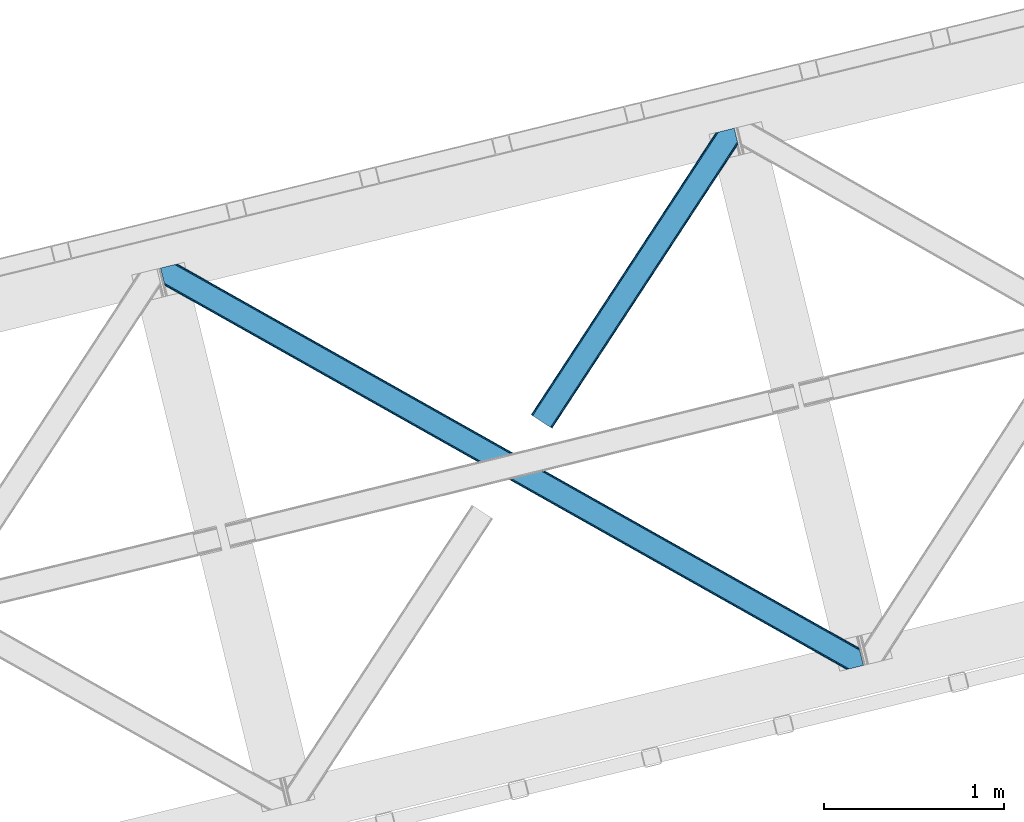
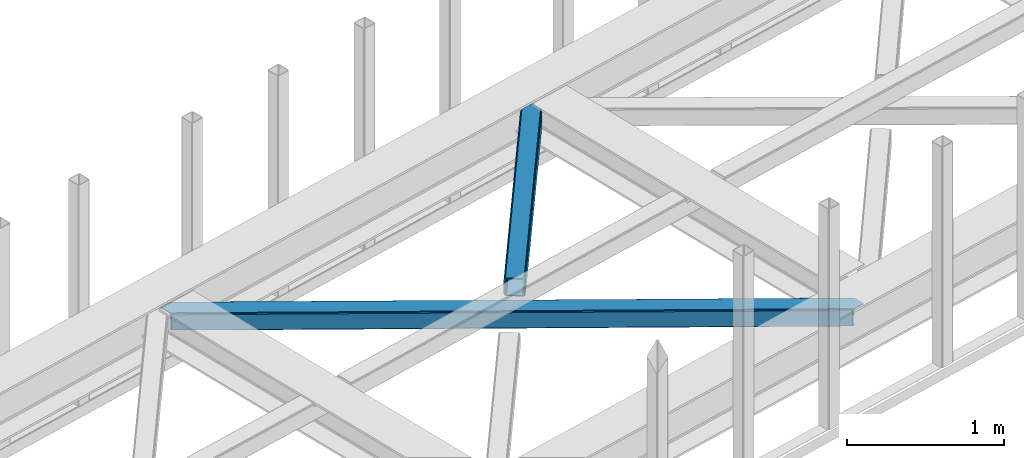
# One storey, part 35 of 66: 2 members.
"""IFC4 building model written with IfcOpenShell, lengths in millimetres."""

import ifcopenshell
import ifcopenshell.guid

model = None  # the IFC model being written
_history = None  # IfcOwnerHistory: only IFC2X3 demands one
_inside = {}  # id of a spatial element -> (the spatial element, [elements in it])
_under = {}  # id of a project, library or spatial element -> (it, [spatial elements below it])
_declared = {}  # id of a project -> (the project, [libraries it declares])
_typed = {}  # id of a type object -> (the type object, [elements of that type])
_made_of = {}  # id of a material, layer set ... -> (it, [elements and type objects made of it])


def new_model(schema):
    """Start an empty IFC model of exactly this schema.

    Asked for "IFC4X3", IfcOpenShell would pick the latest addendum, in which some entities
    have other attributes; the version numbers below select the first issue.
    IFC2X3 requires an IfcOwnerHistory on every rooted entity: one is made here for all.
    """
    global model, _history
    if schema == "IFC4X3":
        model = ifcopenshell.file(schema_version=(4, 3, 0, 0))
    else:
        model = ifcopenshell.file(schema=schema)
    _inside.clear()
    _under.clear()
    _declared.clear()
    _typed.clear()
    _made_of.clear()
    _history = None
    if model.schema == "IFC2X3":
        org = make("IfcOrganization", Name="unknown")
        user = make(
            "IfcPersonAndOrganization",
            ThePerson=make("IfcPerson", FamilyName="unknown"),
            TheOrganization=org,
        )
        app = make(
            "IfcApplication",
            ApplicationDeveloper=org,
            Version="unknown",
            ApplicationFullName="unknown",
            ApplicationIdentifier="unknown",
        )
        _history = make(
            "IfcOwnerHistory",
            OwningUser=user,
            OwningApplication=app,
            ChangeAction="ADDED",
            CreationDate=0,
        )
    return model


def make(cls, **values):
    """One entity of the class cls with the attributes given. An attribute that is None is left unset."""
    return model.create_entity(
        cls, **{name: value for name, value in values.items() if value is not None}
    )


def entity(cls, *values):
    """Any entity or typed value of the class cls, its attributes in the order of the schema. None: left unset."""
    e = model.create_entity(cls)
    for i, value in enumerate(values):
        if value is not None:
            e[i] = value
    return e


def rooted(cls, **values):
    """An entity with a GlobalId (a new one), such as an element, a storey or a relation."""
    return make(cls, GlobalId=ifcopenshell.guid.new(), OwnerHistory=_history, **values)


def si_unit(unit_type, name, prefix=None):
    """IfcSIUnit, for example si_unit("LENGTHUNIT", "METRE", prefix="MILLI")."""
    return make("IfcSIUnit", UnitType=unit_type, Prefix=prefix, Name=name)


def converted_unit(unit_type, name, factor, base, dimensions=None, offset=None):
    """IfcConversionBasedUnit, such as the inch: factor (a typed value) times the base unit."""
    return make(
        "IfcConversionBasedUnit"
        if offset is None
        else "IfcConversionBasedUnitWithOffset",
        ConversionOffset=offset,
        Dimensions=None
        if dimensions is None
        else entity("IfcDimensionalExponents", *dimensions),
        UnitType=unit_type,
        Name=name,
        ConversionFactor=make(
            "IfcMeasureWithUnit", ValueComponent=factor, UnitComponent=base
        ),
    )


def derived_unit(unit_type, elements):
    """IfcDerivedUnit: a product of units, each with its exponent."""
    return make(
        "IfcDerivedUnit",
        Elements=[
            make("IfcDerivedUnitElement", Unit=unit, Exponent=power)
            for unit, power in elements
        ],
        UnitType=unit_type,
    )


def assignment(units):
    """IfcUnitAssignment: the units of a project."""
    return None if units is None else make("IfcUnitAssignment", Units=units)


def point(xyz):
    """IfcCartesianPoint."""
    return None if xyz is None else make("IfcCartesianPoint", Coordinates=xyz)


def direction(xyz):
    """IfcDirection."""
    return None if xyz is None else make("IfcDirection", DirectionRatios=xyz)


def frame(location, z_axis=None, x_axis=None):
    """IfcAxis2Placement3D, a coordinate frame: its origin and axes. An axis left out is left unset."""
    return make(
        "IfcAxis2Placement3D",
        Location=point(location),
        Axis=direction(z_axis),
        RefDirection=direction(x_axis),
    )


def origin():
    """The frame at (0, 0, 0) with its axes left unset."""
    return frame((0.0, 0.0, 0.0))


def place(relative_to, where):
    """IfcLocalPlacement: puts the frame where relative to a parent placement (None: the world)."""
    return make(
        "IfcLocalPlacement", PlacementRelTo=relative_to, RelativePlacement=where
    )


def context(
    kind, dimensions, precision=None, world=None, true_north=None, identifier=None
):
    """IfcGeometricRepresentationContext, for example the 3D "Model" context."""
    return make(
        "IfcGeometricRepresentationContext",
        ContextIdentifier=identifier,
        ContextType=kind,
        CoordinateSpaceDimension=dimensions,
        Precision=precision,
        WorldCoordinateSystem=world,
        TrueNorth=true_north,
    )


def subcontext(parent, identifier, kind, view, scale=None):
    """IfcGeometricRepresentationSubContext, for example "Body" below "Model"."""
    return make(
        "IfcGeometricRepresentationSubContext",
        ContextIdentifier=identifier,
        ContextType=kind,
        ParentContext=parent,
        TargetScale=scale,
        TargetView=view,
    )


def project(units=None, contexts=None):
    """IfcProject with its units and contexts."""
    return rooted(
        "IfcProject",
        Name="project",
        RepresentationContexts=contexts,
        UnitsInContext=assignment(units),
    )


def spatial(cls, under=None, at=None, **own):
    """A site, building, storey or space (cls), placed at a placement, below another one or the project."""
    s = rooted(cls, ObjectPlacement=at, **own)
    if under is not None:
        _under.setdefault(under.id(), (under, []))[1].append(s)
    return s


def point_list(points):
    """IfcCartesianPointList2D or 3D."""
    cls = (
        "IfcCartesianPointList2D" if len(points[0]) == 2 else "IfcCartesianPointList3D"
    )
    return make(cls, CoordList=points)


def triangles(points, corners, closed=None, point_numbers=None):
    """IfcTriangulatedFaceSet: each triangle names its three corners, points numbered from 1."""
    return make(
        "IfcTriangulatedFaceSet",
        Coordinates=point_list(points),
        Closed=closed,
        CoordIndex=corners,
        PnIndex=point_numbers,
    )


def shape(context_of_items, identifier, shape_type, items):
    """IfcShapeRepresentation: the items that make up one representation, for example the "Body"."""
    return make(
        "IfcShapeRepresentation",
        ContextOfItems=context_of_items,
        RepresentationIdentifier=identifier,
        RepresentationType=shape_type,
        Items=items,
    )


def made_of(thing, what):
    """Note that an element or type object is made of a material, layer set ...; save() writes the relation."""
    if what is not None:
        _made_of.setdefault(what.id(), (what, []))[1].append(thing)
    return thing


def type_object(cls, material=None, **own):
    """A type object (cls), such as IfcWallType, which elements share."""
    return made_of(rooted(cls, **own), material)


def element(
    cls,
    number,
    at=None,
    inside=None,
    cuts=None,
    type_object=None,
    material=None,
    context=None,
    identifier="Body",
    shape_type=None,
    held_by="IfcProductDefinitionShape",
    body=None,
    shapes=None,
    **own,
):
    """One element of the class cls, such as IfcWall. Its Tag is "e" and its number.

    at: its placement. inside: the storey or other place that contains it. cuts: it is an
    opening in that element (IfcRelVoidsElement). A single representation is given by context,
    identifier, shape_type and body (its items); several are given by shapes. held_by: the class
    of the entity that holds the representations. save() writes the other relations.
    """
    e = rooted(cls, Tag="e%d" % number, ObjectPlacement=at, **own)
    if body is not None:
        shapes = [shape(context, identifier, shape_type, body)]
    if shapes is not None:
        e.Representation = make(held_by, Representations=shapes)
    if inside is not None:
        _inside.setdefault(inside.id(), (inside, []))[1].append(e)
    if cuts is not None:
        rooted(
            "IfcRelVoidsElement", RelatingBuildingElement=cuts, RelatedOpeningElement=e
        )
    if type_object is not None:
        _typed.setdefault(type_object.id(), (type_object, []))[1].append(e)
    return made_of(e, material)


def aggregate(whole, parts):
    """IfcRelAggregates: a whole, such as a stair, and the parts it consists of."""
    return rooted("IfcRelAggregates", RelatingObject=whole, RelatedObjects=parts)


def save(model, path):
    """Write the relations noted so far, then the file.

    IfcRelAggregates (storeys below a building ...), IfcRelContainedInSpatialStructure (elements
    in a storey), IfcRelDefinesByType, IfcRelAssociatesMaterial and IfcRelDeclares: one each for
    every whole, place, type object, material and project.
    """
    for whole, parts in _under.values():
        aggregate(whole, parts)
    for where, things in _inside.values():
        rooted(
            "IfcRelContainedInSpatialStructure",
            RelatedElements=things,
            RelatingStructure=where,
        )
    for kind, things in _typed.values():
        rooted("IfcRelDefinesByType", RelatedObjects=things, RelatingType=kind)
    for what, things in _made_of.values():
        rooted("IfcRelAssociatesMaterial", RelatedObjects=things, RelatingMaterial=what)
    for by, libraries in _declared.values():
        rooted("IfcRelDeclares", RelatingContext=by, RelatedDefinitions=libraries)
    model.write(path)


model = new_model("IFC4")

# Units and contexts
model_context = context("Model", 3, precision=0.01, world=origin(), true_north=direction((6.12303176911189e-17, 1.0)))
plan_context = context("Plan", 3, precision=0.01, world=origin(), true_north=direction((6.12303176911189e-17, 1.0)))
body_context = subcontext(model_context, "Body", "Model", "MODEL_VIEW")
ifc_project = project(units=[si_unit("LENGTHUNIT", "METRE", prefix="MILLI"), si_unit("AREAUNIT", "SQUARE_METRE"), si_unit("VOLUMEUNIT", "CUBIC_METRE"), converted_unit("PLANEANGLEUNIT", "DEGREE", entity("IfcRatioMeasure", 0.0174532925199433), si_unit("PLANEANGLEUNIT", "RADIAN"), dimensions=[0, 0, 0, 0, 0, 0, 0]), si_unit("MASSUNIT", "GRAM", prefix="KILO"), derived_unit("MASSDENSITYUNIT", [(si_unit("MASSUNIT", "GRAM", prefix="KILO"), 1), (si_unit("LENGTHUNIT", "METRE"), -3)]), derived_unit("MOMENTOFINERTIAUNIT", [(si_unit("LENGTHUNIT", "METRE"), 4)]), si_unit("TIMEUNIT", "SECOND"), si_unit("FREQUENCYUNIT", "HERTZ"), si_unit("THERMODYNAMICTEMPERATUREUNIT", "DEGREE_CELSIUS"), derived_unit("THERMALTRANSMITTANCEUNIT", [(si_unit("MASSUNIT", "GRAM", prefix="KILO"), 1), (si_unit("THERMODYNAMICTEMPERATUREUNIT", "KELVIN"), -1), (si_unit("TIMEUNIT", "SECOND"), -3)]), derived_unit("VOLUMETRICFLOWRATEUNIT", [(si_unit("LENGTHUNIT", "METRE"), 3), (si_unit("TIMEUNIT", "SECOND"), -1)]), derived_unit("MASSFLOWRATEUNIT", [(si_unit("MASSUNIT", "GRAM", prefix="KILO"), 1), (si_unit("TIMEUNIT", "SECOND"), -1)]), derived_unit("ROTATIONALFREQUENCYUNIT", [(si_unit("TIMEUNIT", "SECOND"), -1)]), si_unit("ELECTRICCURRENTUNIT", "AMPERE"), si_unit("ELECTRICVOLTAGEUNIT", "VOLT"), si_unit("POWERUNIT", "WATT"), si_unit("FORCEUNIT", "NEWTON", prefix="KILO"), si_unit("ILLUMINANCEUNIT", "LUX"), si_unit("LUMINOUSFLUXUNIT", "LUMEN"), si_unit("LUMINOUSINTENSITYUNIT", "CANDELA"), derived_unit("USERDEFINED", [(si_unit("MASSUNIT", "GRAM", prefix="KILO"), -1), (si_unit("LENGTHUNIT", "METRE"), -2), (si_unit("TIMEUNIT", "SECOND"), 3), (si_unit("LUMINOUSFLUXUNIT", "LUMEN"), 1)]), derived_unit("LINEARVELOCITYUNIT", [(si_unit("LENGTHUNIT", "METRE"), 1), (si_unit("TIMEUNIT", "SECOND"), -1)]), si_unit("PRESSUREUNIT", "PASCAL"), derived_unit("USERDEFINED", [(si_unit("LENGTHUNIT", "METRE"), -2), (si_unit("MASSUNIT", "GRAM", prefix="KILO"), 1), (si_unit("TIMEUNIT", "SECOND"), -2)]), derived_unit("LINEARFORCEUNIT", [(si_unit("MASSUNIT", "GRAM", prefix="KILO"), 1), (si_unit("LENGTHUNIT", "METRE"), 1), (si_unit("TIMEUNIT", "SECOND"), -2), (si_unit("LENGTHUNIT", "METRE"), -1)]), derived_unit("PLANARFORCEUNIT", [(si_unit("MASSUNIT", "GRAM", prefix="KILO"), 1), (si_unit("LENGTHUNIT", "METRE"), 1), (si_unit("TIMEUNIT", "SECOND"), -2), (si_unit("LENGTHUNIT", "METRE"), -2)])], contexts=[model_context, plan_context])

# Site, building, storey
site_placement = place(None, origin())
site = spatial("IfcSite", under=ifc_project, at=site_placement, CompositionType="ELEMENT")
building_placement = place(site_placement, origin())
building = spatial("IfcBuilding", under=site, at=building_placement, CompositionType="ELEMENT")
storey_placement = place(building_placement, frame((0.0, 0.0, 19800.0)))
storey = spatial("IfcBuildingStorey", under=building, at=storey_placement, Name="06", CompositionType="ELEMENT", Elevation=19800.0)

# Members
member_type_1 = type_object("IfcMemberType", PredefinedType="BRACE")
member_1_placement = place(storey_placement, frame((-36508.39, 9647.05, 3824.0)))
element("IfcMember", 1, at=member_1_placement, inside=storey, type_object=member_type_1, ObjectType="Steel Horizontal Brace", PredefinedType="BRACE", context=body_context, shape_type="Tessellation", body=[
    triangles([(3809.34190063476, 0.0, 122.499499511719), (3811.23480834961, 0.461599731444949, 129.196765136719), (23.4590332031221, 2133.54825897217, 129.196765136719), (23.8915649414048, 2131.77511138916, 122.499499511719), (3816.62982788086, 1.77663574218786, 134.87548828125), (22.2288757324204, 2138.59446258545, 134.87548828125), (3824.70607910156, 3.74570159912037, 138.668280029298), (20.3871276855498, 2146.14632720947, 138.668280029298), (3834.23107910156, 6.06765289306531, 140.00075683594), (18.2151672363252, 2155.05508575439, 140.00075683594), (1916.9806640625, 1065.68088226318, 17.5012573242202), (2556.11839599609, 705.752851867675, 17.5012573242202), (3195.25147705078, 345.823658752441, 17.5012573242202), (3809.34190063476, 0.0, 17.5012573242202), (1277.84758300781, 1425.61007537842, 17.5012573242202), (638.712176513669, 1785.53926849365, 17.5012573242202), (23.8915649414048, 2131.77511138916, 17.5012573242202), (3885.46283569336, 97.7219421386708, 140.00075683594), (3903.67800292969, 22.9956893920898, 140.00075683594), (69.4469238281235, 2246.70995635986, 140.00075683594), (0.0, 2229.78191986084, 140.00075683594), (3883.29087524414, 106.63011932373, 138.668280029298), (78.971923828125, 2249.03190765381, 138.668280029298), (3881.44912719727, 114.183146667479, 134.87548828125), (87.0458496093779, 2251.00039215088, 134.87548828125), (3880.21896972656, 119.229350280761, 129.196765136719), (92.4408691406279, 2252.31542816162, 129.196765136719), (3879.78643798828, 121.001335144043, 122.499499511719), (94.3384277343721, 2252.77702789307, 122.499499511719), (3265.41928710938, 466.982542419433, 17.5012573242202), (3879.78643798828, 121.001335144043, 17.5012573242202), (2626.2955078125, 826.904759216308, 17.5012573242202), (1987.16940307617, 1186.82813873291, 17.5012573242202), (708.921844482422, 1906.67257232666, 17.5012573242202), (94.3384277343721, 2252.77702789307, 17.5012573242202), (1348.0456237793, 1546.75035552978, 17.5012573242202), (82.4856628417983, 2249.88766937256, 122.197192382813), (69.0143920898408, 2246.60531158447, 131.668707275392), (59.4893920898467, 2244.28336029053, 133.001184082033), (0.0, 2229.78191986084, 133.001184082033), (77.0906433105483, 2248.57263336182, 127.873590087893), (84.3808959960952, 2250.35043182373, 24.5008300781265), (77.0906433105483, 2248.57263336182, 12.1248413085959), (91.582781982419, 2252.10613861084, 9.49942016601563), (82.4856628417983, 2249.88766937256, 17.8035644531265), (84.3808959960952, 2250.35043182373, 115.499926757813), (72.3118652343765, 2247.40875091553, 9.49942016601563), (92.0548461914077, 2252.22124786377, 10.8691040039084), (1983.49055786133, 1180.86803741455, 24.5008300781265), (3882.05839233398, 111.689112854003, 115.499926757813), (2626.78850097656, 818.593638610839, 24.5008300781265), (3270.08876953125, 456.319239807128, 24.5008300781265), (3882.05839233398, 111.689112854003, 24.5008300781265), (1340.19028930664, 1543.14127349854, 24.5008300781265), (696.892346191409, 1905.41567230225, 24.5008300781265), (3882.48859863281, 109.917127990722, 122.197192382813), (3883.71875610352, 104.870924377441, 127.873590087893), (3885.56050415039, 97.318478393554, 131.668707275392), (3887.73246459961, 88.4097198486324, 133.001184082033), (3883.71875610352, 104.870924377441, 12.1248413085959), (3885.41865234375, 97.9004196166989, 8.52041015625218), (3880.59104003906, 117.702699279786, 8.52041015625218), (3903.67800292969, 22.9956893920898, 133.001184082033), (3882.48859863281, 109.917127990722, 17.8035644531265), (3880.37477416992, 118.591017150879, 10.9365417480476), (3844.18628540039, 8.49366760253906, 133.001184082033), (15.945538330081, 2164.36730804443, 133.001184082033), (3834.66128540039, 6.17229766845594, 131.668707275392), (18.1174987792983, 2155.45854949951, 131.668707275392), (3826.58735961914, 4.20381317138708, 127.873590087893), (19.959246826169, 2147.90668487549, 127.873590087893), (3821.19001464844, 2.88877716064417, 122.197192382813), (21.1894042968779, 2142.85931854248, 122.197192382813), (3819.29478149414, 2.42659606933557, 115.499926757813), (21.6219360351533, 2141.0873336792, 115.499926757813), (3208.50183105469, 346.395716857909, 24.5008300781265), (3819.29478149414, 2.42659606933557, 24.5008300781265), (2565.16435546875, 708.689881896973, 24.5008300781265), (1921.82920532227, 1070.98520965576, 24.5008300781265), (635.156579589842, 1795.57470245361, 24.5008300781265), (21.6219360351533, 2141.0873336792, 24.5008300781265), (1278.49405517578, 1433.28053741455, 24.5008300781265), (21.1894042968779, 2142.85931854248, 17.8035644531265), (23.263696289061, 2134.3505355835, 9.49942016601563), (19.959246826169, 2147.90668487549, 12.1248413085959), (23.3706665039063, 2133.90986480713, 10.8691040039084), (18.8686157226548, 2152.37617950439, 9.49942016601563), (3826.58735961914, 4.20381317138708, 12.1248413085959), (3812.8672668457, 0.859831237792605, 8.52041015625218), (3821.19001464844, 2.88877716064417, 17.8035644531265), (3834.04039306641, 6.02056274414099, 8.52041015625218), (3811.91848754883, 0.628450012207395, 10.9365417480476), (190.669757080075, 2055.62743377686, 9.49942016601563), (195.064837646481, 2037.60178985596, 9.49942016601563), (196.076403808591, 2037.6692276001, 8.49948120117188), (196.057800292969, 2037.42389373779, 8.8831787109375), (191.292974853517, 2056.67155609131, 8.85294799804615), (195.734564208986, 2037.48202972412, 9.08316650390771), (191.348785400391, 2055.8262588501, 9.20641479492406), (195.385748291017, 2037.54365386963, 9.29943237304906), (191.009271240233, 2055.72626495361, 9.35291748046802), (191.239489746091, 2057.51685333252, 8.49948120117188), (150.921020507813, 2218.69073638916, 9.49942016601563), (155.316101074219, 2200.66509246826, 9.49942016601563), (151.251232910159, 2218.34889678955, 9.25757446289208), (155.811419677731, 2200.23721160889, 9.42500610351635), (151.609350585939, 2217.98496551514, 8.99945068359375), (156.250927734378, 2199.30471038818, 9.11804809570458), (151.96281738281, 2217.619871521, 8.74132690429906), (156.692761230472, 2198.36407012939, 8.80643920898365), (152.295355224611, 2217.27919464111, 8.49948120117188), (157.132269287111, 2197.43156890869, 8.49948120117188), (3713.61751098633, 194.649165344237, 8.52041015625218), (3708.78989868164, 214.452607727051, 8.52041015625218), (3713.26636962891, 194.529405212403, 8.40181274414135), (3708.39922485351, 214.57120513916, 8.37390747070458), (3713.06405639648, 194.459642028809, 8.3320495605476), (3708.00622558594, 214.688639831542, 8.22740478515698), (3707.90623168946, 214.477024841308, 7.87393798828271), (3713.112890625, 193.949208068847, 8.19484863281468), (3707.80623779297, 214.266572570801, 7.52047119140843), (3713.24078979492, 192.705097961425, 7.85765991211156), (3713.36636352539, 191.464476013183, 7.52047119140843), (3264.76583862305, 465.822148132323, 10.8039916992202), (3262.90548706055, 462.516535949706, 5.12526855468968), (3260.11728515625, 457.569163513183, 1.33247680664135), (3708.58293457031, 211.087696838378, 5.59500732422021), (708.268395996092, 1905.51217803955, 10.8039916992202), (706.408044433592, 1902.20772857666, 5.12526855468968), (153.148791503903, 2213.77475738525, 5.12526855468968), (703.622167968751, 1897.26035614014, 1.33247680664135), (154.990539550781, 2206.22289276123, 1.33247680664135), (700.336322021481, 1891.42466583252, 0.0), (157.162499999999, 2197.31413421631, 0.0), (3710.29678344727, 204.050917053222, 1.33247680664135), (3712.46874389648, 195.142158508301, 0.0), (3256.83143920898, 451.734635925293, 0.0), (2625.64205932617, 825.744364929198, 10.8039916992202), (1986.51595458984, 1185.6677444458, 10.8039916992202), (1347.39450073242, 1545.58996124267, 10.8039916992202), (2623.77938232422, 822.438752746582, 5.12526855468968), (1984.65560302734, 1182.36213226318, 5.12526855468968), (1345.53182373047, 1542.28434906006, 5.12526855468968), (2620.99583129883, 817.492543029784, 1.33247680664135), (1981.8697265625, 1177.41475982666, 1.33247680664135), (1342.74594726563, 1537.33813934326, 1.33247680664135), (2617.70765991211, 811.656852722168, 0.0), (1978.58388061523, 1171.58023223877, 0.0), (1339.45777587891, 1531.50244903564, 0.0), (3746.51782836914, 55.4634750366204, 0.0), (3203.83932495117, 361.072727966308, 0.0), (2564.70391845703, 721.000758361815, 0.0), (1925.56851196289, 1080.92995147705, 0.0), (1286.43310546875, 1440.85798187256, 0.0), (647.297698974609, 1800.78717498779, 0.0), (191.209259033203, 2057.6342880249, 0.0), (3195.90492553711, 346.98405303955, 10.8039916992202), (639.365624999999, 1786.69966278076, 10.8039916992202), (641.225976562499, 1790.00527496338, 5.12526855468968), (195.222967529298, 2041.17366485596, 5.12526855468968), (3197.76760253906, 350.290827941893, 5.12526855468968), (3200.55115356445, 355.237037658691, 1.33247680664135), (3748.6874633789, 46.5547164916989, 1.33247680664135), (3752.58024902344, 34.8100845336903, 8.52041015625218), (3750.40363769531, 39.517936706543, 5.59500732422021), (3751.1780090332, 36.3402236938473, 7.52047119140843), (3752.24073486328, 35.1809921264648, 8.278564453125), (644.014178466794, 1794.9526473999, 1.33247680664135), (193.38121948242, 2048.72552947998, 1.33247680664135), (2561.41807250977, 715.166230773926, 1.33247680664135), (1922.28266601563, 1075.09426116943, 1.33247680664135), (1283.14725952149, 1435.02345428467, 1.33247680664135), (2558.63219604492, 710.218858337403, 5.12526855468968), (1919.49678955078, 1070.14805145264, 5.12526855468968), (1280.36370849609, 1430.07724456787, 5.12526855468968), (2556.76951904297, 706.913246154785, 10.8039916992202), (1917.63643798828, 1066.84243927002, 10.8039916992202), (1278.50103149414, 1426.77046966553, 10.8039916992202), (3745.62020874023, 59.1411575317379, 7.52047119140843), (3746.13878173828, 57.3430114746097, 7.90416870117406), (3746.67595825195, 56.436090087891, 8.10880737304615), (3747.30150146484, 55.3762710571282, 8.34832763671875), (3747.75263671875, 54.6129455566406, 8.52041015625218), (3211.01795654297, 350.861723327636, 12.1248413085959), (3217.08967895508, 361.643623352051, 6.99957275390625), (3213.80383300781, 355.80909576416, 8.3320495605476), (3744.24819946289, 64.7751159667969, 6.99957275390625), (643.744427490237, 1810.82377166748, 6.99957275390625), (188.939630126952, 2066.94651031494, 6.99957275390625), (637.672705078126, 1800.04187164307, 12.1248413085959), (640.456256103513, 1804.98808135986, 8.3320495605476), (635.810028076172, 1796.73625946045, 17.8035644531265), (3209.15760498047, 347.556111145019, 17.8035644531265), (2565.82012939453, 709.851438903808, 17.8035644531265), (1922.48265380859, 1072.14560394287, 17.8035644531265), (1279.14517822266, 1434.44093170166, 17.8035644531265), (2567.68048095703, 713.157051086426, 12.1248413085959), (1924.34300537109, 1075.45121612549, 12.1248413085959), (1281.00552978516, 1437.74654388428, 12.1248413085959), (2570.46635742187, 718.103260803222, 8.3320495605476), (1927.13120727539, 1080.39858856201, 8.3320495605476), (1283.79373168945, 1442.69275360107, 8.3320495605476), (2573.75220336914, 723.93895111084, 6.99957275390625), (1930.4147277832, 1086.2331161499, 6.99957275390625), (1287.07957763672, 1448.52844390869, 6.99957275390625), (694.376220703125, 1900.94966583252, 12.1248413085959), (691.58801879883, 1896.002293396, 8.3320495605476), (157.267144775389, 2196.88509063721, 8.41343994140698), (159.43212890625, 2188.00191192627, 6.99957275390625), (3261.50092163086, 441.070170593261, 6.99957275390625), (3264.78676757812, 446.905860900879, 8.3320495605476), (3714.73837280273, 185.831098937988, 6.99957275390625), (3267.57496948242, 451.853233337402, 12.1248413085959), (688.304498291014, 1890.16660308838, 6.99957275390625), (696.236572265625, 1904.25411529541, 17.8035644531265), (3269.43532104492, 455.157682800293, 17.8035644531265), (2621.48882446289, 809.18025970459, 8.3320495605476), (2618.20065307617, 803.344569396972, 6.99957275390625), (1978.1885559082, 1171.45349578857, 8.3320495605476), (1974.90270996094, 1165.61896820068, 6.99957275390625), (1331.60244140625, 1527.89220428467, 6.99957275390625), (1334.89061279297, 1533.72789459228, 8.3320495605476), (2624.27237548828, 814.126469421386, 12.1248413085959), (1980.97443237305, 1176.4008682251, 12.1248413085959), (1337.67416381836, 1538.67526702881, 12.1248413085959), (2626.13737792968, 817.432081604004, 17.8035644531265), (1982.83478393555, 1179.70648040771, 17.8035644531265), (1339.53684082031, 1541.98087921143, 17.8035644531265)], [[1, 2, 3], [3, 4, 1], [2, 5, 6], [6, 3, 2], [5, 7, 8], [8, 6, 5], [7, 9, 10], [10, 8, 7], [11, 1, 4], [1, 12, 13], [11, 12, 1], [13, 14, 1], [15, 4, 16], [4, 15, 11], [17, 16, 4], [9, 18, 10], [9, 19, 18], [20, 10, 18], [21, 10, 20], [18, 22, 23], [23, 20, 18], [22, 24, 25], [25, 23, 22], [24, 26, 27], [27, 25, 24], [26, 28, 29], [29, 27, 26], [30, 28, 31], [28, 30, 32], [28, 33, 29], [33, 28, 32], [34, 35, 29], [36, 29, 33], [29, 36, 34], [37, 29, 27], [38, 23, 20], [21, 39, 20], [39, 21, 40], [39, 38, 20], [41, 23, 38], [41, 37, 25], [25, 23, 41], [27, 25, 37], [42, 35, 29], [43, 44, 45], [37, 46, 29], [43, 47, 44], [42, 45, 35], [46, 42, 29], [48, 35, 45], [45, 44, 48], [49, 50, 46], [50, 51, 52], [49, 51, 50], [52, 53, 50], [54, 46, 55], [46, 54, 49], [42, 55, 46], [50, 56, 46], [37, 46, 56], [56, 57, 37], [41, 37, 57], [57, 58, 41], [38, 41, 58], [58, 59, 38], [39, 38, 59], [57, 24, 22], [60, 61, 62], [24, 57, 56], [58, 57, 22], [58, 18, 59], [19, 59, 18], [59, 19, 63], [58, 22, 18], [31, 28, 53], [62, 64, 60], [64, 31, 53], [65, 64, 62], [65, 31, 64], [28, 50, 53], [56, 26, 24], [28, 26, 56], [50, 28, 56], [59, 66, 67], [66, 59, 63], [67, 39, 59], [40, 39, 67], [66, 68, 67], [69, 67, 68], [68, 70, 69], [71, 69, 70], [70, 72, 71], [73, 71, 72], [72, 74, 73], [75, 73, 74], [76, 74, 77], [74, 76, 78], [74, 79, 75], [79, 74, 78], [80, 81, 75], [82, 75, 79], [75, 82, 80], [83, 84, 85], [81, 4, 17], [17, 86, 83], [86, 84, 83], [83, 81, 17], [75, 4, 81], [73, 71, 6], [3, 73, 6], [3, 4, 73], [75, 73, 4], [71, 8, 6], [69, 8, 71], [87, 85, 84], [69, 67, 10], [69, 10, 8], [67, 21, 10], [67, 40, 21], [72, 1, 2], [68, 7, 9], [19, 66, 9], [66, 19, 63], [66, 68, 9], [70, 7, 68], [70, 72, 5], [5, 7, 70], [2, 5, 72], [77, 14, 1], [88, 89, 90], [72, 74, 1], [88, 91, 89], [77, 90, 14], [74, 77, 1], [92, 14, 90], [90, 89, 92], [93, 94, 84], [84, 87, 93], [95, 96, 97], [96, 98, 99], [99, 98, 100], [101, 100, 94], [94, 93, 101], [100, 101, 99], [99, 97, 96], [97, 102, 95], [103, 104, 44], [47, 44, 104], [105, 106, 104], [107, 108, 106], [109, 110, 108], [111, 112, 110], [110, 109, 111], [108, 107, 109], [106, 105, 107], [104, 103, 105], [62, 61, 113], [113, 114, 62], [115, 116, 114], [117, 118, 116], [116, 115, 117], [119, 118, 120], [121, 119, 122], [122, 123, 121], [120, 122, 119], [117, 120, 118], [114, 113, 115], [124, 30, 31], [125, 124, 118], [118, 119, 125], [119, 121, 125], [124, 65, 114], [114, 116, 124], [116, 118, 124], [65, 62, 114], [126, 125, 127], [48, 128, 103], [128, 129, 130], [130, 111, 128], [128, 109, 107], [109, 128, 111], [128, 105, 103], [105, 128, 107], [128, 48, 35], [35, 34, 128], [103, 44, 48], [129, 131, 132], [132, 130, 129], [131, 133, 134], [134, 132, 131], [135, 136, 137], [137, 126, 135], [127, 135, 126], [121, 127, 125], [31, 65, 124], [30, 124, 138], [138, 32, 30], [32, 138, 33], [139, 33, 138], [33, 139, 36], [140, 36, 139], [36, 140, 34], [128, 34, 140], [124, 125, 138], [141, 138, 125], [138, 141, 142], [142, 139, 138], [139, 142, 143], [143, 140, 139], [140, 143, 129], [129, 128, 140], [125, 126, 144], [144, 141, 125], [141, 144, 145], [145, 142, 141], [142, 145, 146], [146, 143, 142], [143, 146, 129], [131, 129, 146], [126, 137, 144], [147, 144, 137], [144, 147, 145], [148, 145, 147], [145, 148, 146], [149, 146, 148], [146, 149, 131], [133, 131, 149], [136, 150, 151], [137, 151, 147], [151, 137, 136], [148, 152, 153], [152, 147, 151], [148, 147, 152], [133, 149, 154], [153, 149, 148], [149, 153, 154], [155, 133, 154], [156, 133, 155], [134, 133, 156], [157, 92, 14], [158, 16, 17], [159, 96, 95], [158, 86, 94], [94, 159, 158], [94, 98, 159], [86, 84, 94], [95, 160, 159], [161, 162, 163], [92, 157, 164], [157, 161, 165], [165, 166, 157], [167, 164, 157], [157, 166, 167], [164, 89, 92], [163, 165, 161], [150, 163, 162], [162, 151, 150], [155, 168, 169], [169, 156, 155], [168, 159, 160], [160, 169, 168], [17, 86, 158], [14, 13, 157], [151, 162, 152], [170, 152, 162], [152, 170, 153], [171, 153, 170], [153, 171, 172], [172, 154, 153], [154, 172, 168], [168, 155, 154], [162, 161, 170], [173, 170, 161], [170, 173, 174], [174, 171, 170], [171, 174, 175], [175, 172, 171], [172, 175, 168], [159, 168, 175], [161, 157, 176], [176, 173, 161], [173, 176, 174], [177, 174, 176], [174, 177, 175], [178, 175, 177], [175, 178, 159], [158, 159, 178], [157, 13, 12], [12, 176, 157], [176, 12, 11], [11, 177, 176], [177, 11, 15], [15, 178, 177], [178, 15, 16], [16, 158, 178], [166, 179, 180], [166, 180, 181], [167, 181, 182], [167, 182, 183], [91, 89, 183], [164, 183, 89], [184, 183, 182], [88, 91, 183], [183, 184, 88], [185, 180, 179], [182, 185, 186], [182, 181, 185], [180, 185, 181], [179, 187, 185], [188, 189, 102], [93, 85, 190], [93, 87, 85], [102, 190, 191], [190, 102, 97], [97, 99, 190], [80, 192, 81], [83, 81, 192], [192, 190, 83], [85, 83, 190], [102, 191, 188], [182, 186, 184], [90, 88, 184], [184, 193, 90], [77, 90, 193], [193, 76, 77], [76, 193, 78], [194, 78, 193], [78, 194, 79], [195, 79, 194], [79, 195, 82], [196, 82, 195], [82, 196, 80], [192, 80, 196], [193, 184, 197], [197, 194, 193], [194, 197, 195], [198, 195, 197], [195, 198, 199], [199, 196, 195], [196, 199, 190], [190, 192, 196], [184, 186, 197], [200, 197, 186], [197, 200, 201], [201, 198, 197], [198, 201, 202], [202, 199, 198], [199, 202, 191], [191, 190, 199], [186, 185, 203], [203, 200, 186], [200, 203, 201], [204, 201, 203], [201, 204, 202], [205, 202, 204], [202, 205, 191], [188, 191, 205], [206, 106, 108], [108, 207, 206], [108, 110, 207], [110, 208, 207], [104, 206, 43], [43, 47, 104], [207, 208, 209], [210, 123, 122], [122, 211, 210], [122, 117, 211], [210, 212, 123], [213, 211, 117], [61, 60, 113], [213, 113, 60], [209, 214, 207], [206, 215, 45], [45, 43, 206], [215, 55, 42], [42, 45, 215], [64, 53, 216], [52, 216, 53], [60, 64, 213], [216, 213, 64], [210, 211, 217], [217, 218, 210], [218, 217, 219], [219, 220, 218], [220, 219, 221], [222, 221, 219], [221, 222, 207], [207, 214, 221], [211, 213, 217], [223, 217, 213], [217, 223, 219], [224, 219, 223], [219, 224, 222], [225, 222, 224], [222, 225, 206], [206, 207, 222], [213, 216, 226], [226, 223, 213], [223, 226, 227], [227, 224, 223], [224, 227, 228], [228, 225, 224], [225, 228, 206], [215, 206, 228], [216, 52, 51], [51, 226, 216], [226, 51, 227], [49, 227, 51], [227, 49, 228], [54, 228, 49], [228, 54, 215], [55, 215, 54], [209, 134, 189], [132, 208, 130], [208, 132, 134], [130, 208, 111], [134, 209, 208], [189, 134, 156], [169, 102, 156], [102, 169, 160], [156, 102, 189], [160, 95, 102], [136, 212, 187], [123, 127, 121], [136, 123, 212], [123, 135, 127], [123, 136, 135], [150, 136, 187], [179, 150, 187], [165, 179, 166], [179, 163, 150], [179, 165, 163], [203, 185, 210], [210, 218, 203], [218, 204, 203], [204, 218, 220], [185, 212, 210], [185, 187, 212], [214, 188, 221], [188, 214, 189], [209, 189, 214], [205, 221, 188], [220, 205, 204], [221, 205, 220]]),
])
member_type_2 = type_object("IfcMemberType", PredefinedType="BRACE")
member_2_placement = place(storey_placement, frame((-34450.78, 10986.08, 3824.0)))
element("IfcMember", 2, at=member_2_placement, inside=storey, type_object=member_type_2, ObjectType="Steel Horizontal Brace", PredefinedType="BRACE", context=body_context, shape_type="Tessellation", body=[
    triangles([(994.774163818358, 1564.02778930664, 0.0), (1028.82324829101, 1424.34794311523, 0.0), (14.6409667968692, 67.1040435791019, 0.0), (102.486767578121, 9.58662414550781, 0.0), (1.11388549804542, 75.9604797363281, 10.8039916992202), (0.0, 76.6906677246097, 17.5012573242202), (1025.02813110351, 1642.17999572754, 17.5012573242202), (4.28811035156104, 73.8826995849613, 5.12526855468968), (990.476751708979, 1585.8776184082, 9.49942016601563), (990.04654541015, 1584.44747314453, 8.74132690429906), (989.907019042963, 1583.99284973144, 8.49948120117188), (990.762780761717, 1580.48841247559, 5.12526855468968), (1027.30938720703, 1642.73577575684, 10.8691040039084), (1027.78145141601, 1642.85088500977, 9.49942016601563), (992.602203369141, 1572.93654785156, 1.33247680664135), (9.03898315429251, 70.7724243164066, 1.33247680664135), (1025.02813110351, 1642.17999572754, 122.499499511719), (0.0, 76.6906677246097, 122.499499511719), (1026.92103881836, 1642.64159545898, 129.196765136719), (1.11388549804542, 75.9604797363281, 129.196765136719), (1032.31605834961, 1643.95663146973, 134.87548828125), (4.28811035156104, 73.8826995849613, 134.87548828125), (1040.39463500976, 1645.9251159668, 138.668280029298), (9.03898315429251, 70.7724243164066, 138.668280029298), (1049.91963500976, 1648.24706726074, 140.00075683594), (14.6409667968692, 67.1040435791019, 140.00075683594), (994.871832275385, 1567.8519744873, 9.49942016601563), (994.762536621092, 1567.00783996582, 9.2947814941399), (994.648590087891, 1566.15091552734, 9.08781738281323), (994.541619873045, 1565.30678100586, 8.8831787109375), (994.746258544918, 1564.14522399902, 8.49948120117188), (1047.05469360351, 1647.54827270508, 9.49942016601563), (14.8944396972656, 66.9377746582031, 8.3320495605476), (20.4987487792969, 63.2705566406257, 6.99957275390625), (997.043792724609, 1554.7155670166, 6.99957275390625), (10.1458923339815, 70.0480499267578, 12.1248413085959), (1042.27359008789, 1646.38322753906, 12.1248413085959), (1036.87857055664, 1645.06819152832, 17.8035644531265), (1034.98333740234, 1644.60659179688, 24.5008300781265), (6.96934204101126, 72.1258300781246, 17.8035644531265), (5.85545654296584, 72.8560180664063, 24.5008300781265), (1026.55361938477, 1433.66016540527, 6.99957275390625), (96.6289855957002, 13.4212738037113, 6.99957275390625), (1028.71860351562, 1424.77698669434, 8.41343994140698), (1032.83463134765, 1407.88615722656, 5.12526855468968), (1033.6903930664, 1404.38288269043, 8.49948120117188), (1030.99520874023, 1415.43918457031, 1.33247680664135), (1034.98333740234, 1644.60659179688, 115.499926757813), (5.85545654296584, 72.8560180664063, 115.499926757813), (1050.34751586914, 1648.35171203613, 131.668707275392), (1059.87251586914, 1650.67366333008, 133.001184082033), (20.4987487792969, 63.2705566406257, 133.001184082033), (14.8944396972656, 66.9377746582031, 131.668707275392), (1042.27359008789, 1646.38322753906, 127.873590087893), (10.1458923339815, 70.0480499267578, 127.873590087893), (1036.87857055664, 1645.06819152832, 122.197192382813), (6.96934204101126, 72.1258300781246, 122.197192382813), (1128.10788574218, 1667.30636901856, 140.00075683594), (1128.10788574218, 1667.30636901856, 133.001184082033), (1144.33015136718, 1600.75810546875, 140.00075683594), (102.486767578121, 9.58662414550781, 140.00075683594), (1142.06052246093, 1610.07032775879, 133.001184082033), (96.6289855957002, 13.4212738037113, 133.001184082033), (1146.5021118164, 1591.84934692383, 138.668280029298), (108.088751220697, 5.91824340820313, 138.668280029298), (1148.34385986328, 1584.2974822998, 134.87548828125), (112.839624023436, 2.80796813964844, 134.87548828125), (1149.57401733398, 1579.2501159668, 129.196765136719), (116.011523437497, 0.730187988281614, 129.196765136719), (1150.00422363281, 1577.47813110351, 122.499499511719), (117.125408935543, 0.0, 122.499499511719), (1150.00422363281, 1577.47813110351, 17.5012573242202), (117.125408935543, 0.0, 17.5012573242202), (106.981842041016, 6.64261779785193, 127.873590087893), (110.156066894531, 4.5648376464851, 122.197192382813), (111.269952392577, 3.83464965820349, 115.499926757813), (102.233294677731, 9.75289306640661, 131.668707275392), (116.011523437497, 0.730187988281614, 10.8039916992202), (106.981842041016, 6.64261779785193, 12.1248413085959), (112.839624023436, 2.80796813964844, 5.12526855468968), (111.269952392577, 3.83464965820349, 24.5008300781265), (110.156066894531, 4.5648376464851, 17.8035644531265), (108.088751220697, 5.91824340820313, 1.33247680664135), (102.233294677731, 9.75289306640661, 8.3320495605476), (1147.30206298828, 1588.56233825684, 122.197192382813), (1147.73459472656, 1586.79035339356, 115.499926757813), (1146.07190551757, 1593.60854187012, 127.873590087893), (1144.23248291016, 1601.16156921387, 131.668707275392), (1147.73459472656, 1586.79035339356, 24.5008300781265), (1147.21369628906, 1588.92510681152, 17.8686767578147), (1149.994921875, 1577.51650085449, 16.5013183593765), (1147.10672607421, 1589.36577758789, 16.5013183593765), (1145.27660522461, 1573.10863037109, 10.8714294433594), (1034.62056884765, 1404.788671875, 9.49942016601563), (1144.12783813477, 1572.03544006348, 9.49942016601563), (1142.79303588867, 1588.59838256836, 12.1248413085959), (1030.22548828125, 1422.8143157959, 9.49942016601563), (1029.19764404296, 1423.6724029541, 8.80643920898365), (1139.73275756836, 1590.06108398438, 9.49942016601563)], [[1, 2, 3], [4, 3, 2], [5, 6, 7], [8, 9, 10], [11, 12, 8], [5, 13, 9], [9, 8, 5], [13, 14, 9], [15, 1, 16], [3, 16, 1], [12, 15, 8], [16, 8, 15], [7, 13, 5], [17, 7, 6], [6, 18, 17], [19, 17, 20], [18, 20, 17], [21, 19, 22], [20, 22, 19], [23, 21, 24], [22, 24, 21], [25, 23, 26], [24, 26, 23], [27, 28, 9], [28, 29, 10], [29, 30, 10], [30, 31, 11], [14, 32, 27], [27, 9, 14], [33, 34, 35], [36, 33, 31], [31, 30, 36], [28, 36, 29], [28, 27, 36], [36, 30, 29], [32, 37, 27], [36, 27, 37], [35, 31, 33], [38, 39, 40], [41, 40, 39], [37, 38, 36], [40, 36, 38], [42, 35, 34], [34, 43, 42], [1, 35, 42], [31, 12, 11], [1, 31, 35], [31, 15, 12], [31, 1, 15], [2, 1, 42], [44, 2, 42], [45, 44, 46], [44, 47, 2], [44, 45, 47], [39, 48, 49], [49, 41, 39], [50, 51, 52], [52, 53, 50], [54, 50, 53], [53, 55, 54], [56, 54, 55], [55, 57, 56], [48, 56, 57], [57, 49, 48], [56, 17, 19], [50, 23, 25], [58, 51, 25], [51, 58, 59], [51, 50, 25], [54, 23, 50], [54, 56, 21], [21, 23, 54], [19, 21, 56], [39, 7, 17], [37, 14, 38], [56, 48, 17], [37, 32, 14], [39, 38, 7], [48, 39, 17], [13, 7, 38], [38, 14, 13], [60, 25, 61], [25, 60, 58], [26, 61, 25], [51, 62, 63], [51, 59, 62], [63, 52, 51], [64, 60, 61], [61, 65, 64], [66, 64, 65], [65, 67, 66], [68, 66, 67], [67, 69, 68], [70, 68, 69], [69, 71, 70], [72, 70, 71], [71, 73, 72], [69, 74, 75], [76, 73, 71], [69, 75, 71], [69, 67, 74], [75, 76, 71], [74, 67, 65], [63, 61, 26], [61, 77, 65], [77, 61, 63], [77, 74, 65], [78, 79, 80], [81, 73, 76], [73, 82, 78], [82, 73, 81], [78, 82, 79], [4, 43, 3], [83, 80, 79], [79, 84, 83], [84, 43, 4], [4, 83, 84], [55, 24, 22], [26, 52, 63], [26, 53, 52], [53, 26, 24], [55, 53, 24], [49, 18, 6], [20, 57, 55], [22, 20, 55], [57, 20, 18], [49, 57, 18], [16, 36, 8], [3, 43, 34], [34, 33, 3], [33, 36, 16], [16, 3, 33], [5, 8, 36], [6, 41, 49], [40, 6, 5], [6, 40, 41], [40, 5, 36], [85, 86, 75], [76, 75, 86], [87, 85, 74], [75, 74, 85], [88, 87, 77], [74, 77, 87], [62, 88, 63], [77, 63, 88], [86, 89, 76], [81, 76, 89], [90, 91, 92], [70, 72, 89], [72, 90, 89], [89, 86, 70], [72, 91, 90], [85, 70, 86], [68, 70, 85], [66, 85, 87], [85, 66, 68], [87, 64, 66], [88, 64, 87], [88, 62, 60], [88, 60, 64], [62, 58, 60], [62, 59, 58], [73, 78, 93], [93, 72, 73], [94, 93, 78], [94, 95, 93], [80, 45, 46], [46, 78, 80], [46, 94, 78], [47, 45, 83], [80, 83, 45], [2, 47, 4], [83, 4, 47], [93, 91, 72], [82, 81, 89], [82, 92, 96], [82, 90, 92], [84, 97, 98], [79, 96, 97], [97, 84, 79], [96, 99, 97], [43, 84, 44], [44, 42, 43], [96, 79, 82], [89, 90, 82], [96, 91, 93], [96, 92, 91], [96, 95, 99], [93, 95, 96], [99, 95, 97], [94, 97, 95]]),
])

save(model, "model.ifc")
